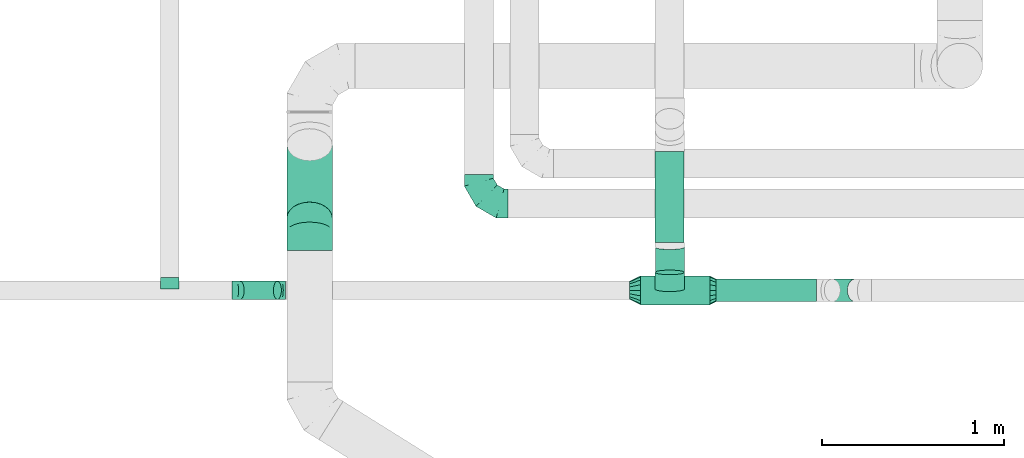
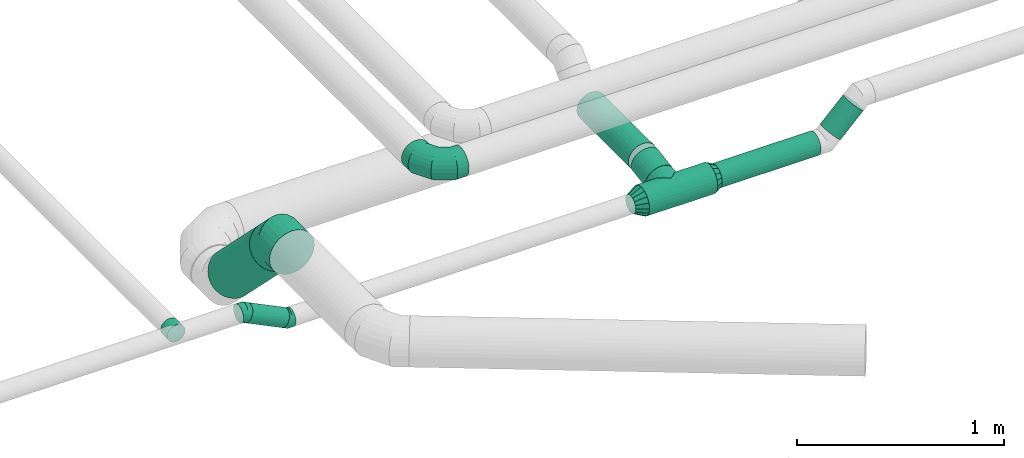
# One storey, part 6 of 60: 8 flow fittings, 7 flow segments.
"""IFC2X3 building model written with IfcOpenShell, lengths in millimetres."""

from ifc_helpers import new_model, entity, si_unit, converted_unit, derived_unit, direction, frame, origin, origin_2d_with_axis, place, context, subcontext, project, spatial, circle, extrude, faceted_brep, source, transform, mapped, material, type_object, type_shapes, element, save


model = new_model("IFC2X3")

# Units and contexts
model_context = context("Model", 3, precision=0.01, world=origin(), true_north=direction((6.12303176911189e-17, 1.0)))
body_context = subcontext(model_context, "Body", "Model", "MODEL_VIEW")
ifc_project = project(units=[si_unit("LENGTHUNIT", "METRE", prefix="MILLI"), si_unit("AREAUNIT", "SQUARE_METRE"), si_unit("VOLUMEUNIT", "CUBIC_METRE"), converted_unit("PLANEANGLEUNIT", "DEGREE", entity("IfcRatioMeasure", 0.0174532925199433), si_unit("PLANEANGLEUNIT", "RADIAN"), dimensions=[0, 0, 0, 0, 0, 0, 0]), si_unit("MASSUNIT", "GRAM", prefix="KILO"), derived_unit("MASSDENSITYUNIT", [(si_unit("MASSUNIT", "GRAM", prefix="KILO"), 1), (si_unit("LENGTHUNIT", "METRE"), -3)]), derived_unit("MOMENTOFINERTIAUNIT", [(si_unit("LENGTHUNIT", "METRE"), 4)]), si_unit("TIMEUNIT", "SECOND"), si_unit("FREQUENCYUNIT", "HERTZ"), si_unit("THERMODYNAMICTEMPERATUREUNIT", "DEGREE_CELSIUS"), derived_unit("THERMALTRANSMITTANCEUNIT", [(si_unit("MASSUNIT", "GRAM", prefix="KILO"), 1), (si_unit("THERMODYNAMICTEMPERATUREUNIT", "KELVIN"), -1), (si_unit("TIMEUNIT", "SECOND"), -3)]), derived_unit("VOLUMETRICFLOWRATEUNIT", [(si_unit("LENGTHUNIT", "METRE"), 3), (si_unit("TIMEUNIT", "SECOND"), -1)]), derived_unit("MASSFLOWRATEUNIT", [(si_unit("MASSUNIT", "GRAM", prefix="KILO"), 1), (si_unit("TIMEUNIT", "SECOND"), -1)]), derived_unit("ROTATIONALFREQUENCYUNIT", [(si_unit("TIMEUNIT", "SECOND"), -1)]), si_unit("ELECTRICCURRENTUNIT", "AMPERE"), si_unit("ELECTRICVOLTAGEUNIT", "VOLT"), si_unit("POWERUNIT", "WATT"), si_unit("FORCEUNIT", "NEWTON", prefix="KILO"), si_unit("ILLUMINANCEUNIT", "LUX"), si_unit("LUMINOUSFLUXUNIT", "LUMEN"), si_unit("LUMINOUSINTENSITYUNIT", "CANDELA"), derived_unit("USERDEFINED", [(si_unit("MASSUNIT", "GRAM", prefix="KILO"), -1), (si_unit("LENGTHUNIT", "METRE"), -2), (si_unit("TIMEUNIT", "SECOND"), 3), (si_unit("LUMINOUSFLUXUNIT", "LUMEN"), 1)]), derived_unit("LINEARVELOCITYUNIT", [(si_unit("LENGTHUNIT", "METRE"), 1), (si_unit("TIMEUNIT", "SECOND"), -1)]), si_unit("PRESSUREUNIT", "PASCAL"), derived_unit("USERDEFINED", [(si_unit("LENGTHUNIT", "METRE"), -2), (si_unit("MASSUNIT", "GRAM", prefix="KILO"), 1), (si_unit("TIMEUNIT", "SECOND"), -2)]), derived_unit("LINEARFORCEUNIT", [(si_unit("MASSUNIT", "GRAM", prefix="KILO"), 1), (si_unit("LENGTHUNIT", "METRE"), 1), (si_unit("TIMEUNIT", "SECOND"), -2), (si_unit("LENGTHUNIT", "METRE"), -1)]), derived_unit("PLANARFORCEUNIT", [(si_unit("MASSUNIT", "GRAM", prefix="KILO"), 1), (si_unit("LENGTHUNIT", "METRE"), 1), (si_unit("TIMEUNIT", "SECOND"), -2), (si_unit("LENGTHUNIT", "METRE"), -2)])], contexts=[model_context])

# Site, building, storey
site_placement = place(None, origin())
site = spatial("IfcSite", under=ifc_project, at=site_placement, CompositionType="ELEMENT")
building_placement = place(site_placement, origin())
building = spatial("IfcBuilding", under=site, at=building_placement, CompositionType="ELEMENT")
storey_placement = place(building_placement, frame((0.0, 0.0, 19800.0)))
storey = spatial("IfcBuildingStorey", under=building, at=storey_placement, CompositionType="ELEMENT", Elevation=19800.0)

# Flow segments
duct_segment_type = type_object("IfcDuctSegmentType", PredefinedType="NOTDEFINED")
flow_segment_1_placement = place(storey_placement, frame((8068.1, 11862.56, 3408.4)))
element("IfcFlowSegment", 1, at=flow_segment_1_placement, inside=storey, type_object=duct_segment_type, context=body_context, shape_type="SweptSolid", body=[
    extrude(circle(Radius=80.0, at=origin_2d_with_axis()), frame((81.6, 0.0, 81.6), z_axis=(0.0, 1.0, 0.0), x_axis=(-1.0, 0.0, 0.0)), (0.0, 0.0, 1.0), 501.000534914337),
])
flow_segment_2_placement = place(storey_placement, frame((7989.69, 11518.37, 3368.4)))
element("IfcFlowSegment", 2, at=flow_segment_2_placement, inside=storey, type_object=duct_segment_type, context=body_context, shape_type="SweptSolid", body=[
    extrude(circle(Radius=80.0, at=origin_2d_with_axis()), frame((0.0, 81.6, 81.6), z_axis=(1.0, 0.0, 0.0), x_axis=(0.0, -1.0, 0.0)), (0.0, 0.0, 1.0), 380.0),
])
flow_segment_3_placement = place(storey_placement, frame((8404.69, 11535.87, 3385.9)))
element("IfcFlowSegment", 3, at=flow_segment_3_placement, inside=storey, type_object=duct_segment_type, context=body_context, shape_type="SweptSolid", body=[
    extrude(circle(Radius=62.5, at=origin_2d_with_axis()), frame((0.0, 64.1, 64.1), z_axis=(1.0, 0.0, 0.0), x_axis=(0.0, -1.0, 0.0)), (0.0, 0.0, 1.0), 550.723304703368),
])
flow_segment_4_placement = place(storey_placement, frame((8998.02, 11535.87, 3440.82)))
element("IfcFlowSegment", 4, at=flow_segment_4_placement, inside=storey, type_object=duct_segment_type, context=body_context, shape_type="SweptSolid", body=[
    extrude(circle(Radius=62.5, at=origin_2d_with_axis()), frame((45.79, 64.1, 45.79), z_axis=(0.707106781186508, 0.0, 0.707106781186587), x_axis=(0.0, -1.0, 0.0)), (0.0, 0.0, 1.0), 179.289321881459),
])
flow_segment_5_placement = place(storey_placement, frame((8068.1, 11684.46, 3385.22)))
element("IfcFlowSegment", 5, at=flow_segment_5_placement, inside=storey, type_object=duct_segment_type, context=body_context, shape_type="SweptSolid", body=[
    extrude(circle(Radius=80.0, at=origin_2d_with_axis()), frame((81.6, 14.24, 80.59), z_axis=(0.0, 0.987428495005975, 0.158066338131287), x_axis=(1.0, 0.0, 0.0)), (0.0, 0.0, 1.0), 140.333012392542),
])
flow_segment_6_placement = place(storey_placement, frame((5764.68, 11548.37, 3413.59)))
element("IfcFlowSegment", 6, at=flow_segment_6_placement, inside=storey, type_object=duct_segment_type, context=body_context, shape_type="SweptSolid", body=[
    extrude(circle(Radius=50.0, at=origin_2d_with_axis()), frame((23.52, 51.6, 146.29), z_axis=(0.898768445643889, 0.0, -0.438423632021436), x_axis=(0.0, 1.0, 0.0)), (0.0, 0.0, 1.0), 227.528084352686),
])
flow_segment_7_placement = place(storey_placement, frame((6043.16, 11906.67, 3083.33)))
element("IfcFlowSegment", 7, at=flow_segment_7_placement, inside=storey, type_object=duct_segment_type, context=body_context, shape_type="SweptSolid", body=[
    extrude(circle(Radius=125.0, at=origin_2d_with_axis()), frame((126.6, 493.45, 89.98), z_axis=(0.0, -0.707106781186544, 0.707106781186551), x_axis=(1.0, 0.0, 0.0)), (0.0, 0.0, 1.0), 570.583286532263),
])

# Flow fittings
ifc_material = material()
duct_fitting_type_1 = type_object("IfcDuctFittingType", PredefinedType="NOTDEFINED", material=ifc_material)
shared_shape_1 = source(origin(), body_context, "Body", "Brep", [
    faceted_brep([(-160.0, 0.0, -80.0), (-160.0, -20.71, -77.27), (-160.0, -40.0, -69.28), (-160.0, -56.57, -56.57), (-160.0, -69.28, -40.0), (-160.0, -77.27, -20.71), (-160.0, -80.0, 0.0), (-160.0, -77.27, 20.71), (-160.0, -69.28, 40.0), (-160.0, -56.57, 56.57), (-160.0, -40.0, 69.28), (-160.0, -20.71, 77.27), (-160.0, 0.0, 80.0), (-160.0, 20.71, 77.27), (-160.0, 40.0, 69.28), (-160.0, 56.57, 56.57), (-160.0, 69.28, 40.0), (-160.0, 77.27, 20.71), (-160.0, 80.0, 0.0), (-160.0, 77.27, -20.71), (-160.0, 69.28, -40.0), (-160.0, 56.57, -56.57), (-160.0, 40.0, -69.28), (-160.0, 20.71, -77.27), (-122.68, 20.71, 77.27), (-127.85, 40.0, 69.28), (-117.13, 0.0, 80.0), (-132.29, 56.57, 56.57), (-137.83, 77.27, 20.71), (-138.56, 80.0, 0.0), (-135.69, 69.28, 40.0), (-135.69, 69.28, -40.0), (-132.29, 56.57, -56.57), (-137.83, 77.27, -20.71), (-122.68, 20.71, -77.27), (-117.13, 0.0, -80.0), (-127.85, 40.0, -69.28), (-111.58, -20.71, -77.27), (-106.41, -40.0, -69.28), (-101.97, -56.57, -56.57), (-98.56, -69.28, -40.0), (-96.42, -77.27, -20.71), (-95.69, -80.0, 0.0), (-96.42, -77.27, 20.71), (-98.56, -69.28, 40.0), (-101.97, -56.57, 56.57), (-106.41, -40.0, 69.28), (-111.58, -20.71, 77.27), (-58.03, 58.03, 77.27), (-72.15, 72.15, 69.28), (-42.87, 42.87, 80.0), (-84.28, 84.28, 56.57), (-93.59, 93.59, 40.0), (-99.44, 99.44, 20.71), (-101.44, 101.44, 0.0), (-99.44, 99.44, -20.71), (-93.59, 93.59, -40.0), (-84.28, 84.28, -56.57), (-58.03, 58.03, -77.27), (-42.87, 42.87, -80.0), (-72.15, 72.15, -69.28), (-27.71, 27.71, -77.27), (-13.59, 13.59, -69.28), (-1.46, 1.46, -56.57), (7.85, -7.85, -40.0), (13.7, -13.7, -20.71), (15.69, -15.69, 0.0), (13.7, -13.7, 20.71), (7.85, -7.85, 40.0), (-1.46, 1.46, 56.57), (-13.59, 13.59, 69.28), (-27.71, 27.71, 77.27), (-20.71, 122.68, 77.27), (-40.0, 127.85, 69.28), (0.0, 117.13, 80.0), (-56.57, 132.29, 56.57), (-69.28, 135.69, 40.0), (-77.27, 137.83, 20.71), (-80.0, 138.56, 0.0), (-77.27, 137.83, -20.71), (-69.28, 135.69, -40.0), (-56.57, 132.29, -56.57), (-20.71, 122.68, -77.27), (0.0, 117.13, -80.0), (-40.0, 127.85, -69.28), (20.71, 111.58, -77.27), (40.0, 106.41, -69.28), (56.57, 101.97, -56.57), (69.28, 98.56, -40.0), (77.27, 96.42, -20.71), (80.0, 95.69, 0.0), (77.27, 96.42, 20.71), (69.28, 98.56, 40.0), (56.57, 101.97, 56.57), (40.0, 106.41, 69.28), (20.71, 111.58, 77.27), (-20.71, 160.0, -77.27), (-40.0, 160.0, -69.28), (-56.57, 160.0, -56.57), (-69.28, 160.0, -40.0), (-77.27, 160.0, -20.71), (-80.0, 160.0, 0.0), (-77.27, 160.0, 20.71), (-69.28, 160.0, 40.0), (-56.57, 160.0, 56.57), (-40.0, 160.0, 69.28), (-20.71, 160.0, 77.27), (0.0, 160.0, 80.0), (20.71, 160.0, 77.27), (40.0, 160.0, 69.28), (56.57, 160.0, 56.57), (69.28, 160.0, 40.0), (77.27, 160.0, 20.71), (80.0, 160.0, 0.0), (77.27, 160.0, -20.71), (69.28, 160.0, -40.0), (56.57, 160.0, -56.57), (40.0, 160.0, -69.28), (20.71, 160.0, -77.27), (0.0, 160.0, -80.0)], [[[0, 1, 2, 3, 4, 5, 6, 7, 8, 9, 10, 11, 12, 13, 14, 15, 16, 17, 18, 19, 20, 21, 22, 23]], [[24, 25, 14, 13]], [[26, 24, 13, 12]], [[14, 25, 27, 15]], [[28, 29, 18, 17]], [[30, 28, 17, 16]], [[15, 27, 30, 16]], [[20, 31, 32, 21]], [[33, 31, 20, 19]], [[18, 29, 33, 19]], [[34, 35, 0, 23]], [[36, 34, 23, 22]], [[32, 36, 22, 21]], [[1, 0, 35, 37]], [[2, 1, 37, 38]], [[3, 2, 38, 39]], [[5, 4, 40, 41]], [[6, 5, 41, 42]], [[39, 40, 4, 3]], [[6, 42, 43, 7]], [[7, 43, 44, 8]], [[8, 44, 45, 9]], [[9, 45, 46, 10]], [[10, 46, 47, 11]], [[26, 12, 11, 47]], [[48, 49, 25, 24]], [[50, 48, 24, 26]], [[27, 25, 49, 51]], [[52, 53, 28, 30]], [[51, 52, 30, 27]], [[29, 28, 53, 54]], [[55, 56, 31, 33]], [[54, 55, 33, 29]], [[32, 31, 56, 57]], [[58, 59, 35, 34]], [[60, 58, 34, 36]], [[57, 60, 36, 32]], [[37, 35, 59, 61]], [[38, 37, 61, 62]], [[39, 38, 62, 63]], [[41, 40, 64, 65]], [[42, 41, 65, 66]], [[63, 64, 40, 39]], [[43, 42, 66, 67]], [[44, 43, 67, 68]], [[68, 69, 45, 44]], [[46, 45, 69, 70]], [[47, 46, 70, 71]], [[26, 47, 71, 50]], [[72, 73, 49, 48]], [[74, 72, 48, 50]], [[51, 49, 73, 75]], [[76, 77, 53, 52]], [[75, 76, 52, 51]], [[54, 53, 77, 78]], [[79, 80, 56, 55]], [[78, 79, 55, 54]], [[57, 56, 80, 81]], [[82, 83, 59, 58]], [[84, 82, 58, 60]], [[81, 84, 60, 57]], [[61, 59, 83, 85]], [[62, 61, 85, 86]], [[63, 62, 86, 87]], [[65, 64, 88, 89]], [[66, 65, 89, 90]], [[87, 88, 64, 63]], [[67, 66, 90, 91]], [[68, 67, 91, 92]], [[92, 93, 69, 68]], [[70, 69, 93, 94]], [[71, 70, 94, 95]], [[50, 71, 95, 74]], [[96, 97, 98, 99, 100, 101, 102, 103, 104, 105, 106, 107, 108, 109, 110, 111, 112, 113, 114, 115, 116, 117, 118, 119]], [[72, 74, 107, 106]], [[73, 72, 106, 105]], [[75, 73, 105, 104]], [[77, 76, 103, 102]], [[78, 77, 102, 101]], [[75, 104, 103, 76]], [[78, 101, 100, 79]], [[79, 100, 99, 80]], [[80, 99, 98, 81]], [[84, 97, 96, 82]], [[82, 96, 119, 83]], [[84, 81, 98, 97]], [[118, 117, 86, 85]], [[119, 118, 85, 83]], [[116, 87, 86, 117]], [[88, 115, 114, 89]], [[89, 114, 113, 90]], [[115, 88, 87, 116]], [[112, 111, 92, 91]], [[113, 112, 91, 90]], [[111, 110, 93, 92]], [[95, 94, 109, 108]], [[74, 95, 108, 107]], [[110, 109, 94, 93]]]),
])
type_shapes(duct_fitting_type_1, [shared_shape_1])
flow_fitting_1_placement = place(storey_placement, frame((7100.03, 12077.58, 3650.0), z_axis=(0.0, 0.0, 1.0), x_axis=(0.0, -1.0, 0.0)))
element("IfcFlowFitting", 8, at=flow_fitting_1_placement, inside=storey, type_object=duct_fitting_type_1, material=ifc_material, context=body_context, shape_type="MappedRepresentation", body=[
    mapped(shared_shape_1, transform((0.0, 0.0, 0.0), scale=1.0)),
])
duct_fitting_type_2 = type_object("IfcDuctFittingType", PredefinedType="NOTDEFINED", material=ifc_material)
shared_shape_2 = source(origin(), body_context, "Body", "Brep", [
    faceted_brep([(35.0, -57.74, 23.92), (35.0, -60.12, 11.96), (35.0, -62.5, 0.0), (35.0, -60.12, -11.96), (35.0, -57.74, -23.92), (35.0, -50.97, -34.06), (35.0, -44.19, -44.19), (35.0, -34.06, -50.97), (35.0, -23.92, -57.74), (35.0, -11.96, -60.12), (35.0, 0.0, -62.5), (35.0, 11.96, -60.12), (35.0, 23.92, -57.74), (35.0, 34.06, -50.97), (35.0, 44.19, -44.19), (35.0, 50.97, -34.06), (35.0, 57.74, -23.92), (35.0, 60.12, -11.96), (35.0, 62.5, 0.0), (35.0, 60.12, 11.96), (35.0, 57.74, 23.92), (35.0, 50.97, 34.06), (35.0, 44.19, 44.19), (35.0, 34.06, 50.97), (35.0, 23.92, 57.74), (35.0, 11.96, 60.12), (35.0, 0.0, 62.5), (35.0, -11.96, 60.12), (35.0, -23.92, 57.74), (35.0, -34.06, 50.97), (35.0, -44.19, 44.19), (35.0, -50.97, 34.06), (0.0, -80.0, 0.0), (0.0, -77.45, 12.81), (0.0, -73.91, 30.61), (0.0, -65.24, 43.59), (0.0, -56.57, 56.57), (0.0, -43.59, 65.24), (0.0, -30.61, 73.91), (0.0, -12.81, 77.45), (0.0, 0.0, 80.0), (0.0, 12.81, 77.45), (0.0, 30.61, 73.91), (0.0, 43.59, 65.24), (0.0, 56.57, 56.57), (0.0, 65.24, 43.59), (0.0, 73.91, 30.61), (0.0, 77.45, 12.81), (0.0, 80.0, 0.0), (0.0, 77.45, -12.81), (0.0, 73.91, -30.61), (0.0, 65.24, -43.59), (0.0, 56.57, -56.57), (0.0, 43.59, -65.24), (0.0, 30.61, -73.91), (0.0, 12.81, -77.45), (0.0, 0.0, -80.0), (0.0, -12.81, -77.45), (0.0, -30.61, -73.91), (0.0, -43.59, -65.24), (0.0, -56.57, -56.57), (0.0, -65.24, -43.59), (0.0, -73.91, -30.61), (0.0, -77.45, -12.81)], [[[0, 1, 2, 3, 4, 5, 6, 7, 8, 9, 10, 11, 12, 13, 14, 15, 16, 17, 18, 19, 20, 21, 22, 23, 24, 25, 26, 27, 28, 29, 30, 31]], [[32, 33, 34, 35, 36, 37, 38, 39, 40, 41, 42, 43, 44, 45, 46, 47, 48, 49, 50, 51, 52, 53, 54, 55, 56, 57, 58, 59, 60, 61, 62, 63]], [[24, 23, 22, 44, 43, 42]], [[20, 46, 45, 44, 22, 21]], [[42, 41, 40, 26, 25, 24]], [[47, 46, 20, 19, 18, 48]], [[0, 31, 30, 36, 35, 34]], [[28, 38, 37, 36, 30, 29]], [[34, 33, 32, 2, 1, 0]], [[39, 38, 28, 27, 26, 40]], [[8, 7, 6, 60, 59, 58]], [[4, 62, 61, 60, 6, 5]], [[58, 57, 56, 10, 9, 8]], [[63, 62, 4, 3, 2, 32]], [[16, 15, 14, 52, 51, 50]], [[12, 54, 53, 52, 14, 13]], [[50, 49, 48, 18, 17, 16]], [[55, 54, 12, 11, 10, 56]]]),
])
type_shapes(duct_fitting_type_2, [shared_shape_2])
flow_fitting_2_placement = place(storey_placement, frame((8369.69, 11599.96, 3450.0)))
element("IfcFlowFitting", 9, at=flow_fitting_2_placement, inside=storey, type_object=duct_fitting_type_2, material=ifc_material, context=body_context, shape_type="MappedRepresentation", body=[
    mapped(shared_shape_2, transform((0.0, 0.0, 0.0), scale=1.0)),
])
duct_fitting_type_3 = type_object("IfcDuctFittingType", PredefinedType="NOTDEFINED", material=ifc_material)
shared_shape_3 = source(origin(), body_context, "Body", "Brep", [
    faceted_brep([(60.0, -46.19, 19.13), (60.0, -48.1, 9.57), (60.0, -50.0, 0.0), (60.0, -48.1, -9.57), (60.0, -46.19, -19.13), (60.0, -40.77, -27.24), (60.0, -35.36, -35.36), (60.0, -27.24, -40.77), (60.0, -19.13, -46.19), (60.0, -9.57, -48.1), (60.0, 0.0, -50.0), (60.0, 9.57, -48.1), (60.0, 19.13, -46.19), (60.0, 27.24, -40.77), (60.0, 35.36, -35.36), (60.0, 40.77, -27.24), (60.0, 46.19, -19.13), (60.0, 48.1, -9.57), (60.0, 50.0, 0.0), (60.0, 48.1, 9.57), (60.0, 46.19, 19.13), (60.0, 40.77, 27.24), (60.0, 35.36, 35.36), (60.0, 27.24, 40.77), (60.0, 19.13, 46.19), (60.0, 9.57, 48.1), (60.0, 0.0, 50.0), (60.0, -9.57, 48.1), (60.0, -19.13, 46.19), (60.0, -27.24, 40.77), (60.0, -35.36, 35.36), (60.0, -40.77, 27.24), (0.0, -80.0, 0.0), (0.0, -77.16, 14.27), (0.0, -73.91, 30.61), (0.0, -65.24, 43.59), (0.0, -56.57, 56.57), (0.0, -43.59, 65.24), (0.0, -30.61, 73.91), (0.0, -15.31, 76.96), (0.0, 0.0, 80.0), (0.0, 14.27, 77.16), (0.0, 30.61, 73.91), (0.0, 43.59, 65.24), (0.0, 56.57, 56.57), (0.0, 65.24, 43.59), (0.0, 73.91, 30.61), (0.0, 76.96, 15.31), (0.0, 80.0, 0.0), (0.0, 77.16, -14.27), (0.0, 73.91, -30.61), (0.0, 65.24, -43.59), (0.0, 56.57, -56.57), (0.0, 43.59, -65.24), (0.0, 30.61, -73.91), (0.0, 15.31, -76.96), (0.0, 0.0, -80.0), (0.0, -14.27, -77.16), (0.0, -30.61, -73.91), (0.0, -43.59, -65.24), (0.0, -56.57, -56.57), (0.0, -65.24, -43.59), (0.0, -73.91, -30.61), (0.0, -76.96, -15.31)], [[[0, 1, 2, 3, 4, 5, 6, 7, 8, 9, 10, 11, 12, 13, 14, 15, 16, 17, 18, 19, 20, 21, 22, 23, 24, 25, 26, 27, 28, 29, 30, 31]], [[32, 33, 34, 35, 36, 37, 38, 39, 40, 41, 42, 43, 44, 45, 46, 47, 48, 49, 50, 51, 52, 53, 54, 55, 56, 57, 58, 59, 60, 61, 62, 63]], [[42, 41, 40, 26, 25, 24]], [[43, 42, 24, 23, 22, 44]], [[20, 46, 45, 44, 22, 21]], [[18, 48, 47, 46, 20, 19]], [[34, 33, 32, 2, 1, 0]], [[35, 34, 0, 31, 30, 36]], [[28, 38, 37, 36, 30, 29]], [[26, 40, 39, 38, 28, 27]], [[58, 57, 56, 10, 9, 8]], [[59, 58, 8, 7, 6, 60]], [[4, 62, 61, 60, 6, 5]], [[2, 32, 63, 62, 4, 3]], [[50, 49, 48, 18, 17, 16]], [[51, 50, 16, 15, 14, 52]], [[12, 54, 53, 52, 14, 13]], [[10, 56, 55, 54, 12, 11]]]),
])
type_shapes(duct_fitting_type_3, [shared_shape_3])
flow_fitting_3_placement = place(storey_placement, frame((7989.69, 11599.96, 3450.0), z_axis=(0.0, 0.0, 1.0), x_axis=(-1.0, 0.0, 0.0)))
element("IfcFlowFitting", 10, at=flow_fitting_3_placement, inside=storey, type_object=duct_fitting_type_3, material=ifc_material, context=body_context, shape_type="MappedRepresentation", body=[
    mapped(shared_shape_3, transform((0.0, 0.0, 0.0), scale=1.0)),
])
duct_fitting_type_4 = type_object("IfcDuctFittingType", PredefinedType="NOTDEFINED", material=ifc_material)
shared_shape_4 = source(origin(), body_context, "Body", "Brep", [
    faceted_brep([(20.0, 12.94, -48.3), (20.0, 25.0, -43.3), (20.0, 35.36, -35.36), (20.0, 43.3, -25.0), (20.0, 48.3, -12.94), (20.0, 50.0, 0.0), (20.0, 48.3, 12.94), (20.0, 43.3, 25.0), (20.0, 35.36, 35.36), (20.0, 25.0, 43.3), (20.0, 12.94, 48.3), (20.0, 0.0, 50.0), (20.0, -12.94, 48.3), (20.0, -25.0, 43.3), (20.0, -35.36, 35.36), (20.0, -43.3, 25.0), (20.0, -48.3, 12.94), (20.0, -50.0, 0.0), (20.0, -48.3, -12.94), (20.0, -43.3, -25.0), (20.0, -35.36, -35.36), (20.0, -25.0, -43.3), (20.0, -12.94, -48.3), (20.0, 0.0, -50.0), (0.0, 0.0, 50.0), (0.0, 12.94, 48.3), (-43.9, 12.94, 48.3), (-43.9, 0.0, 50.0), (0.0, 25.0, 43.3), (-43.9, 25.0, 43.3), (0.0, 35.36, 35.36), (-43.9, 35.36, 35.36), (0.0, 43.3, 25.0), (0.0, 48.3, 12.94), (-43.9, 48.3, 12.94), (-43.9, 43.3, 25.0), (0.0, 50.0, 0.0), (-43.9, 50.0, 0.0), (0.0, 48.3, -12.94), (-43.9, 48.3, -12.94), (0.0, 43.3, -25.0), (-43.9, 43.3, -25.0), (0.0, 35.36, -35.36), (-43.9, 35.36, -35.36), (0.0, 25.0, -43.3), (0.0, 12.94, -48.3), (-43.9, 12.94, -48.3), (-43.9, 25.0, -43.3), (0.0, 0.0, -50.0), (-43.9, 0.0, -50.0), (0.0, -12.94, -48.3), (-43.9, -12.94, -48.3), (0.0, -25.0, -43.3), (-43.9, -25.0, -43.3), (0.0, -35.36, -35.36), (-43.9, -35.36, -35.36), (0.0, -43.3, -25.0), (0.0, -48.3, -12.94), (-43.9, -48.3, -12.94), (-43.9, -43.3, -25.0), (0.0, -50.0, 0.0), (-43.9, -50.0, 0.0), (0.0, -48.3, 12.94), (-43.9, -48.3, 12.94), (0.0, -43.3, 25.0), (-43.9, -43.3, 25.0), (0.0, -35.36, 35.36), (-43.9, -35.36, 35.36), (0.0, -25.0, 43.3), (0.0, -12.94, 48.3), (-43.9, -12.94, 48.3), (-43.9, -25.0, 43.3)], [[[0, 1, 2, 3, 4, 5, 6, 7, 8, 9, 10, 11, 12, 13, 14, 15, 16, 17, 18, 19, 20, 21, 22, 23]], [[24, 11, 10, 25, 26, 27]], [[25, 10, 9, 28, 29, 26]], [[28, 9, 8, 30, 31, 29]], [[32, 7, 6, 33, 34, 35]], [[33, 6, 5, 36, 37, 34]], [[30, 8, 7, 32, 35, 31]], [[36, 5, 4, 38, 39, 37]], [[38, 4, 3, 40, 41, 39]], [[40, 3, 2, 42, 43, 41]], [[44, 1, 0, 45, 46, 47]], [[45, 0, 23, 48, 49, 46]], [[42, 2, 1, 44, 47, 43]], [[48, 23, 22, 50, 51, 49]], [[50, 22, 21, 52, 53, 51]], [[52, 21, 20, 54, 55, 53]], [[56, 19, 18, 57, 58, 59]], [[57, 18, 17, 60, 61, 58]], [[54, 20, 19, 56, 59, 55]], [[60, 17, 16, 62, 63, 61]], [[62, 16, 15, 64, 65, 63]], [[64, 15, 14, 66, 67, 65]], [[68, 13, 12, 69, 70, 71]], [[69, 12, 11, 24, 27, 70]], [[66, 14, 13, 68, 71, 67]], [[49, 51, 53, 55, 59, 58, 61, 63, 65, 67, 71, 70, 27, 26, 29, 31, 35, 34, 37, 39, 41, 43, 47, 46]]]),
])
type_shapes(duct_fitting_type_4, [shared_shape_4])
flow_fitting_4_placement = place(storey_placement, frame((5400.44, 11649.96, 3570.0), z_axis=(0.0, 0.0, -1.0), x_axis=(0.0, 1.0, 0.0)))
element("IfcFlowFitting", 11, at=flow_fitting_4_placement, inside=storey, type_object=duct_fitting_type_4, material=ifc_material, context=body_context, shape_type="MappedRepresentation", body=[
    mapped(shared_shape_4, transform((0.0, 0.0, 0.0), scale=1.0)),
])
duct_fitting_type_5 = type_object("IfcDuctFittingType", PredefinedType="NOTDEFINED", material=ifc_material)
shared_shape_5 = source(origin(), body_context, "Body", "Brep", [
    faceted_brep([(-103.55, 0.0, -125.0), (-103.55, -32.35, -120.74), (-103.55, -62.5, -108.25), (-103.55, -88.39, -88.39), (-103.55, -108.25, -62.5), (-103.55, -120.74, -32.35), (-103.55, -125.0, 0.0), (-103.55, -120.74, 32.35), (-103.55, -108.25, 62.5), (-103.55, -88.39, 88.39), (-103.55, -62.5, 108.25), (-103.55, -32.35, 120.74), (-103.55, 0.0, 125.0), (-103.55, 32.35, 120.74), (-103.55, 62.5, 108.25), (-103.55, 88.39, 88.39), (-103.55, 108.25, 62.5), (-103.55, 120.74, 32.35), (-103.55, 125.0, 0.0), (-103.55, 120.74, -32.35), (-103.55, 108.25, -62.5), (-103.55, 88.39, -88.39), (-103.55, 62.5, -108.25), (-103.55, 32.35, -120.74), (-13.4, 32.35, 120.74), (-25.89, 62.5, 108.25), (0.0, 0.0, 125.0), (-36.61, 88.39, 88.39), (-44.84, 108.25, 62.5), (-50.01, 120.74, 32.35), (-51.78, 125.0, 0.0), (-50.01, 120.74, -32.35), (-44.84, 108.25, -62.5), (-36.61, 88.39, -88.39), (-13.4, 32.35, -120.74), (0.0, 0.0, -125.0), (-25.89, 62.5, -108.25), (13.4, -32.35, -120.74), (25.89, -62.5, -108.25), (36.61, -88.39, -88.39), (44.84, -108.25, -62.5), (50.01, -120.74, -32.35), (51.78, -125.0, 0.0), (50.01, -120.74, 32.35), (44.84, -108.25, 62.5), (36.61, -88.39, 88.39), (25.89, -62.5, 108.25), (13.4, -32.35, 120.74), (73.22, 73.22, 125.0), (50.35, 96.1, 120.74), (29.03, 117.42, 108.25), (10.72, 135.72, 88.39), (-3.32, 149.77, 62.5), (-12.15, 158.6, 32.35), (-15.17, 161.61, 0.0), (-12.15, 158.6, -32.35), (-3.32, 149.77, -62.5), (10.72, 135.72, -88.39), (29.03, 117.42, -108.25), (50.35, 96.1, -120.74), (73.22, 73.22, -125.0), (96.1, 50.35, -120.74), (117.42, 29.03, -108.25), (135.72, 10.72, -88.39), (149.77, -3.32, -62.5), (158.6, -12.15, -32.35), (161.61, -15.17, 0.0), (158.6, -12.15, 32.35), (149.77, -3.32, 62.5), (135.72, 10.72, 88.39), (117.42, 29.03, 108.25), (96.1, 50.35, 120.74)], [[[0, 1, 2, 3, 4, 5, 6, 7, 8, 9, 10, 11, 12, 13, 14, 15, 16, 17, 18, 19, 20, 21, 22, 23]], [[24, 25, 14, 13]], [[26, 24, 13, 12]], [[14, 25, 27, 15]], [[28, 29, 17, 16]], [[28, 16, 15, 27]], [[30, 18, 17, 29]], [[31, 32, 20, 19]], [[30, 31, 19, 18]], [[32, 33, 21, 20]], [[34, 35, 0, 23]], [[36, 34, 23, 22]], [[33, 36, 22, 21]], [[1, 0, 35, 37]], [[2, 1, 37, 38]], [[38, 39, 3, 2]], [[5, 4, 40, 41]], [[6, 5, 41, 42]], [[39, 40, 4, 3]], [[6, 42, 43, 7]], [[7, 43, 44, 8]], [[8, 44, 45, 9]], [[9, 45, 46, 10]], [[10, 46, 47, 11]], [[26, 12, 11, 47]], [[24, 26, 48, 49]], [[25, 24, 49, 50]], [[27, 25, 50, 51]], [[29, 28, 52, 53]], [[30, 29, 53, 54]], [[51, 52, 28, 27]], [[30, 54, 55, 31]], [[31, 55, 56, 32]], [[57, 33, 32, 56]], [[36, 58, 59, 34]], [[34, 59, 60, 35]], [[58, 36, 33, 57]], [[35, 60, 61, 37]], [[37, 61, 62, 38]], [[63, 39, 38, 62]], [[40, 64, 65, 41]], [[41, 65, 66, 42]], [[64, 40, 39, 63]], [[43, 42, 66, 67]], [[44, 43, 67, 68]], [[68, 69, 45, 44]], [[47, 46, 70, 71]], [[26, 47, 71, 48]], [[69, 70, 46, 45]], [[59, 58, 57, 56, 55, 54, 53, 52, 51, 50, 49, 48, 71, 70, 69, 68, 67, 66, 65, 64, 63, 62, 61, 60]]]),
])
type_shapes(duct_fitting_type_5, [shared_shape_5])
flow_fitting_5_placement = place(storey_placement, frame((6169.75, 11923.43, 3650.0), z_axis=(-1.0, 0.0, 0.0), x_axis=(0.0, 1.0, 0.0)))
element("IfcFlowFitting", 12, at=flow_fitting_5_placement, inside=storey, type_object=duct_fitting_type_5, material=ifc_material, context=body_context, shape_type="MappedRepresentation", body=[
    mapped(shared_shape_5, transform((0.0, 0.0, 0.0), scale=1.0)),
])
duct_fitting_type_6 = type_object("IfcDuctFittingType", PredefinedType="NOTDEFINED", material=ifc_material)
shared_shape_6 = source(origin(), body_context, "Body", "Brep", [
    faceted_brep([(20.0, 0.0, -80.0), (20.0, 20.71, -77.27), (20.0, 40.0, -69.28), (20.0, 56.57, -56.57), (20.0, 69.28, -40.0), (20.0, 77.27, -20.71), (20.0, 80.0, 0.0), (20.0, 77.27, 20.71), (20.0, 69.28, 40.0), (20.0, 56.57, 56.57), (20.0, 40.0, 69.28), (20.0, 20.71, 77.27), (20.0, 0.0, 80.0), (20.0, -20.71, 77.27), (20.0, -40.0, 69.28), (20.0, -56.57, 56.57), (20.0, -69.28, 40.0), (20.0, -77.27, 20.71), (20.0, -80.0, 0.0), (20.0, -77.27, -20.71), (20.0, -69.28, -40.0), (20.0, -56.57, -56.57), (20.0, -40.0, -69.28), (20.0, -20.71, -77.27), (0.0, 0.0, 80.0), (-73.9, 0.0, 80.0), (-73.9, -20.71, 77.27), (0.0, -20.71, 77.27), (-73.9, -40.0, 69.28), (0.0, -40.0, 69.28), (0.0, -56.57, 56.57), (-73.9, -56.57, 56.57), (0.0, -69.28, 40.0), (-73.9, -69.28, 40.0), (-73.9, -77.27, 20.71), (0.0, -77.27, 20.71), (-73.9, -80.0, 0.0), (0.0, -80.0, 0.0), (-73.9, -77.27, -20.71), (0.0, -77.27, -20.71), (-73.9, -69.28, -40.0), (0.0, -69.28, -40.0), (0.0, -56.57, -56.57), (-73.9, -56.57, -56.57), (0.0, -40.0, -69.28), (-73.9, -40.0, -69.28), (-73.9, -20.71, -77.27), (0.0, -20.71, -77.27), (-73.9, 0.0, -80.0), (0.0, 0.0, -80.0), (-73.9, 20.71, -77.27), (0.0, 20.71, -77.27), (-73.9, 40.0, -69.28), (0.0, 40.0, -69.28), (0.0, 56.57, -56.57), (-73.9, 56.57, -56.57), (0.0, 69.28, -40.0), (-73.9, 69.28, -40.0), (-73.9, 77.27, -20.71), (0.0, 77.27, -20.71), (-73.9, 80.0, 0.0), (0.0, 80.0, 0.0), (-73.9, 77.27, 20.71), (0.0, 77.27, 20.71), (-73.9, 69.28, 40.0), (0.0, 69.28, 40.0), (0.0, 56.57, 56.57), (-73.9, 56.57, 56.57), (0.0, 40.0, 69.28), (-73.9, 40.0, 69.28), (-73.9, 20.71, 77.27), (0.0, 20.71, 77.27)], [[[0, 1, 2, 3, 4, 5, 6, 7, 8, 9, 10, 11, 12, 13, 14, 15, 16, 17, 18, 19, 20, 21, 22, 23]], [[13, 12, 24, 25, 26, 27]], [[14, 13, 27, 26, 28, 29]], [[30, 15, 14, 29, 28, 31]], [[17, 16, 32, 33, 34, 35]], [[18, 17, 35, 34, 36, 37]], [[32, 16, 15, 30, 31, 33]], [[19, 18, 37, 36, 38, 39]], [[20, 19, 39, 38, 40, 41]], [[42, 21, 20, 41, 40, 43]], [[23, 22, 44, 45, 46, 47]], [[0, 23, 47, 46, 48, 49]], [[44, 22, 21, 42, 43, 45]], [[1, 0, 49, 48, 50, 51]], [[2, 1, 51, 50, 52, 53]], [[54, 3, 2, 53, 52, 55]], [[5, 4, 56, 57, 58, 59]], [[6, 5, 59, 58, 60, 61]], [[56, 4, 3, 54, 55, 57]], [[7, 6, 61, 60, 62, 63]], [[8, 7, 63, 62, 64, 65]], [[66, 9, 8, 65, 64, 67]], [[11, 10, 68, 69, 70, 71]], [[12, 11, 71, 70, 25, 24]], [[68, 10, 9, 66, 67, 69]], [[46, 45, 43, 40, 38, 36, 34, 33, 31, 28, 26, 25, 70, 69, 67, 64, 62, 60, 58, 57, 55, 52, 50, 48]]]),
])
type_shapes(duct_fitting_type_6, [shared_shape_6])
flow_fitting_6_placement = place(storey_placement, frame((8149.69, 11678.96, 3462.65), z_axis=(0.0, 0.158066338131321, -0.98742849500597), x_axis=(0.0, 0.98742849500597, 0.158066338131321)))
element("IfcFlowFitting", 13, at=flow_fitting_6_placement, inside=storey, type_object=duct_fitting_type_6, material=ifc_material, context=body_context, shape_type="MappedRepresentation", body=[
    mapped(shared_shape_6, transform((0.0, 0.0, 0.0), scale=1.0)),
])
duct_fitting_type_7 = type_object("IfcDuctFittingType", PredefinedType="NOTDEFINED", material=ifc_material)
shared_shape_7 = source(origin(), body_context, "Body", "Brep", [
    faceted_brep([(-23.09, 0.0, -50.0), (-23.09, -12.94, -48.3), (-23.09, -25.0, -43.3), (-23.09, -35.36, -35.36), (-23.09, -43.3, -25.0), (-23.09, -48.3, -12.94), (-23.09, -50.0, 0.0), (-23.09, -48.3, 12.94), (-23.09, -43.3, 25.0), (-23.09, -35.36, 35.36), (-23.09, -25.0, 43.3), (-23.09, -12.94, 48.3), (-23.09, 0.0, 50.0), (-23.09, 12.94, 48.3), (-23.09, 25.0, 43.3), (-23.09, 35.36, 35.36), (-23.09, 43.3, 25.0), (-23.09, 48.3, 12.94), (-23.09, 50.0, 0.0), (-23.09, 48.3, -12.94), (-23.09, 43.3, -25.0), (-23.09, 35.36, -35.36), (-23.09, 25.0, -43.3), (-23.09, 12.94, -48.3), (-2.99, 12.94, 48.3), (-5.77, 25.0, 43.3), (0.0, 0.0, 50.0), (-8.16, 35.36, 35.36), (-11.15, 48.3, 12.94), (-11.54, 50.0, 0.0), (-10.0, 43.3, 25.0), (-10.0, 43.3, -25.0), (-8.16, 35.36, -35.36), (-11.15, 48.3, -12.94), (-2.99, 12.94, -48.3), (0.0, 0.0, -50.0), (-5.77, 25.0, -43.3), (2.99, -12.94, -48.3), (5.77, -25.0, -43.3), (8.16, -35.36, -35.36), (10.0, -43.3, -25.0), (11.15, -48.3, -12.94), (11.54, -50.0, 0.0), (11.15, -48.3, 12.94), (10.0, -43.3, 25.0), (8.16, -35.36, 35.36), (5.77, -25.0, 43.3), (2.99, -12.94, 48.3), (20.75, 10.12, 50.0), (15.08, 21.75, 48.3), (9.79, 32.59, 43.3), (5.25, 41.9, 35.36), (1.77, 49.04, 25.0), (-0.42, 53.53, 12.94), (-1.17, 55.06, 0.0), (-0.42, 53.53, -12.94), (1.77, 49.04, -25.0), (5.25, 41.9, -35.36), (15.08, 21.75, -48.3), (20.75, 10.12, -50.0), (9.79, 32.59, -43.3), (26.43, -1.51, -48.3), (31.71, -12.35, -43.3), (36.25, -21.65, -35.36), (41.93, -33.28, -12.94), (42.67, -34.82, 0.0), (39.74, -28.79, -25.0), (41.93, -33.28, 12.94), (39.74, -28.79, 25.0), (36.25, -21.65, 35.36), (31.71, -12.35, 43.3), (26.43, -1.51, 48.3)], [[[0, 1, 2, 3, 4, 5, 6, 7, 8, 9, 10, 11, 12, 13, 14, 15, 16, 17, 18, 19, 20, 21, 22, 23]], [[24, 25, 14, 13]], [[26, 24, 13, 12]], [[14, 25, 27, 15]], [[28, 29, 18, 17]], [[30, 28, 17, 16]], [[15, 27, 30, 16]], [[20, 31, 32, 21]], [[33, 31, 20, 19]], [[18, 29, 33, 19]], [[34, 35, 0, 23]], [[36, 34, 23, 22]], [[32, 36, 22, 21]], [[2, 1, 37, 38]], [[3, 2, 38, 39]], [[0, 35, 37, 1]], [[5, 4, 40, 41]], [[6, 5, 41, 42]], [[39, 40, 4, 3]], [[6, 42, 43, 7]], [[7, 43, 44, 8]], [[8, 44, 45, 9]], [[10, 46, 47, 11]], [[11, 47, 26, 12]], [[9, 45, 46, 10]], [[24, 26, 48, 49]], [[25, 24, 49, 50]], [[27, 25, 50, 51]], [[28, 30, 52, 53]], [[29, 28, 53, 54]], [[27, 51, 52, 30]], [[29, 54, 55, 33]], [[33, 55, 56, 31]], [[31, 56, 57, 32]], [[58, 59, 35, 34]], [[60, 58, 34, 36]], [[36, 32, 57, 60]], [[35, 59, 61, 37]], [[37, 61, 62, 38]], [[38, 62, 63, 39]], [[64, 65, 42, 41]], [[66, 64, 41, 40]], [[39, 63, 66, 40]], [[43, 42, 65, 67]], [[44, 43, 67, 68]], [[45, 44, 68, 69]], [[47, 46, 70, 71]], [[26, 47, 71, 48]], [[69, 70, 46, 45]], [[58, 60, 57, 56, 55, 54, 53, 52, 51, 50, 49, 48, 71, 70, 69, 68, 67, 65, 64, 66, 63, 62, 61, 59]]]),
])
type_shapes(duct_fitting_type_7, [shared_shape_7])
for number, where, z_axis, x_axis in (
    (14, (6013.44, 11599.96, 3450.0), (0.0, 1.0, 0.0), (-1.0, 0.0, 0.0)),
    (15, (5767.44, 11599.96, 3570.0), (0.0, 1.0, 0.0), (1.0, 0.0, 0.0)),
):
    element("IfcFlowFitting", number, at=place(storey_placement, frame(where, z_axis=z_axis, x_axis=x_axis)), inside=storey, type_object=duct_fitting_type_7, material=ifc_material, context=body_context, shape_type="MappedRepresentation", body=[
        mapped(shared_shape_7, transform((0.0, 0.0, 0.0), scale=1.0)),
    ])

save(model, "model.ifc")
